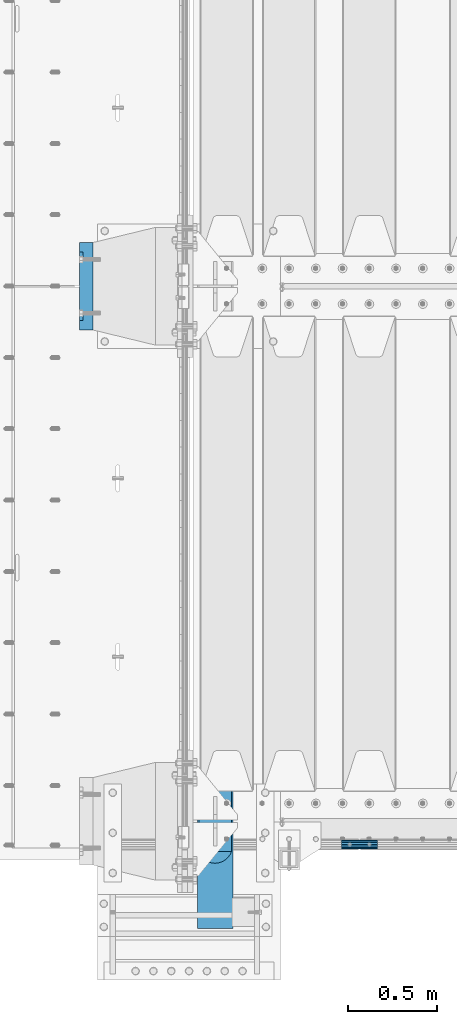
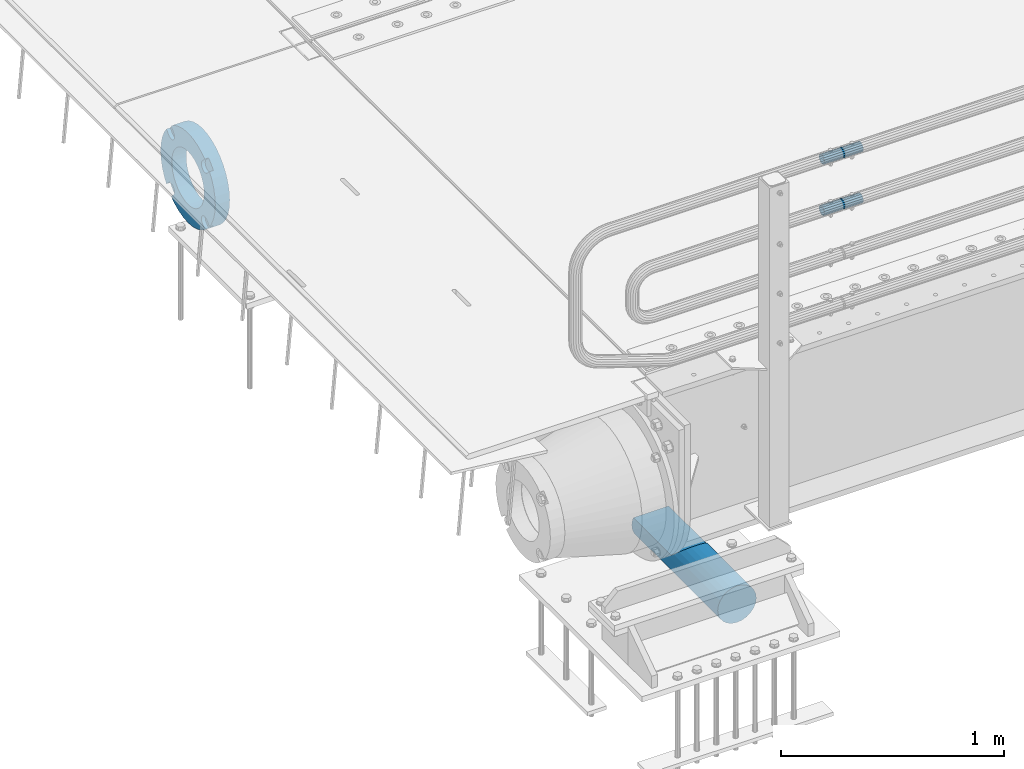
# One storey, part 138 of 257: 4 beams.
"""IFC2X3 building model written with IfcOpenShell, lengths in millimetres."""

from ifc_helpers import new_model, si_unit, frame, origin_with_axes, place, context, subcontext, project, spatial, faceted_brep, material, type_object, element, save


model = new_model("IFC2X3")

# Units and contexts
model_context = context("Model", 3, precision=1e-05, world=origin_with_axes())
body_context = subcontext(model_context, "Body", "Model", "MODEL_VIEW")
ifc_project = project(units=[si_unit("LENGTHUNIT", "METRE", prefix="MILLI"), si_unit("AREAUNIT", "SQUARE_METRE"), si_unit("VOLUMEUNIT", "CUBIC_METRE"), si_unit("MASSUNIT", "GRAM", prefix="KILO"), si_unit("TIMEUNIT", "SECOND"), si_unit("PLANEANGLEUNIT", "RADIAN"), si_unit("SOLIDANGLEUNIT", "STERADIAN"), si_unit("THERMODYNAMICTEMPERATUREUNIT", "DEGREE_CELSIUS"), si_unit("LUMINOUSINTENSITYUNIT", "LUMEN")], contexts=[model_context])

# Site, building, storey
site_placement = place(None, origin_with_axes())
site = spatial("IfcSite", under=ifc_project, at=site_placement, CompositionType="ELEMENT")
building_placement = place(site_placement, origin_with_axes())
building = spatial("IfcBuilding", under=site, at=building_placement, Name="Standard", CompositionType="ELEMENT")
storey_placement = place(building_placement, origin_with_axes())
storey = spatial("IfcBuildingStorey", under=building, at=storey_placement, Name="Undefined", CompositionType="ELEMENT", Elevation=0.0)

# Beams
ifc_material_1 = material(Name="STEEL/S355N")
beam_type_1 = type_object("IfcBeamType", Name="D200", PredefinedType="NOTDEFINED")
beam_1_placement = place(storey_placement, frame((42585.0, -600.0, -928.0), z_axis=(0.0, 0.0, 1.0), x_axis=(0.0, 1.0, 0.0)))
element("IfcBeam", 1, at=beam_1_placement, inside=storey, type_object=beam_type_1, material=ifc_material_1, ObjectType="D200", context=body_context, shape_type="Brep", body=[
    faceted_brep([(417.294117647059, 86.6025403784442, 50.0), (395.365164344954, 70.7106781186521, 70.7106781186548), (378.538486658119, 50.0, 86.6025403784439), (367.960794863511, 25.88190451025, 96.5925826289068), (364.352941176472, 0.0, 100.0), (367.960794863511, -25.88190451025, 96.5925826289068), (378.538486658119, -50.0, 86.6025403784439), (395.365164344954, -70.7106781186521, 70.7106781186548), (417.294117647059, -86.6025403784442, 50.0), (430.0, -91.5731031269243, 38.0), (430.0, 91.5731031269243, 38.0), (770.0, -91.5731031269243, 37.9999999999994), (770.0, 91.5731031269243, 37.9999999999994), (0.0, -96.5925826289094, 25.8819045102521), (0.0, -86.6025403784442, 50.0), (0.0, -70.7106781186521, 70.7106781186548), (0.0, -50.0, 86.6025403784439), (0.0, -25.88190451025, 96.5925826289068), (0.0, 0.0, 100.0), (0.0, 25.88190451025, 96.5925826289068), (0.0, 50.0, 86.6025403784439), (0.0, 70.7106781186521, 70.7106781186548), (0.0, 86.6025403784442, 50.0), (0.0, 96.5925826289094, 25.8819045102521), (0.0, 100.0, 0.0), (0.0, 96.5925826289094, -25.8819045102521), (0.0, 86.6025403784442, -50.0), (0.0, 70.7106781186521, -70.7106781186548), (0.0, 50.0, -86.6025403784438), (0.0, 25.88190451025, -96.5925826289067), (0.0, 0.0, -100.0), (0.0, -25.88190451025, -96.5925826289069), (0.0, -50.0, -86.6025403784439), (0.0, -70.7106781186521, -70.7106781186548), (0.0, -86.6025403784442, -50.0), (0.0, -96.5925826289094, -25.8819045102522), (0.0, -100.0, 0.0), (770.0, 96.5925826289094, 25.8819045102521), (770.0, 100.0, 0.0), (770.0, 96.5925826289094, -25.8819045102521), (770.0, 86.6025403784442, -50.0), (770.0, 70.7106781186521, -70.7106781186548), (770.0, 50.0, -86.6025403784438), (770.0, 25.88190451025, -96.5925826289067), (770.0, 0.0, -100.0), (770.0, -25.88190451025, -96.5925826289069), (770.0, -50.0, -86.6025403784439), (770.0, -70.7106781186521, -70.7106781186548), (770.0, -86.6025403784442, -50.0), (770.0, -96.5925826289094, -25.8819045102522), (770.0, -100.0, 0.0), (770.0, -96.5925826289094, 25.8819045102521)], [[[0, 1, 2, 3, 4, 5, 6, 7, 8, 9, 10]], [[10, 9, 11, 12]], [[13, 14, 15, 16, 17, 18, 19, 20, 21, 22, 23, 24, 25, 26, 27, 28, 29, 30, 31, 32, 33, 34, 35, 36]], [[24, 23, 37, 38]], [[25, 24, 38, 39]], [[26, 25, 39, 40]], [[27, 26, 40, 41]], [[28, 27, 41, 42]], [[29, 28, 42, 43]], [[30, 29, 43, 44]], [[31, 30, 44, 45]], [[32, 31, 45, 46]], [[33, 32, 46, 47]], [[34, 33, 47, 48]], [[35, 34, 48, 49]], [[36, 35, 49, 50]], [[13, 36, 50, 51]], [[14, 13, 51, 11, 9, 8]], [[15, 14, 8, 7]], [[16, 15, 7, 6]], [[17, 16, 6, 5]], [[18, 17, 5, 4]], [[19, 18, 4, 3]], [[20, 19, 3, 2]], [[21, 20, 2, 1]], [[22, 21, 1, 0]], [[37, 23, 22, 0, 10, 12]], [[51, 50, 49, 48, 47, 46, 45, 44, 43, 42, 41, 40, 39, 38, 37, 12, 11]]]),
])
ifc_material_2 = material()
beam_type_2 = type_object("IfcBeamType", PredefinedType="NOTDEFINED")
beam_2_placement = place(storey_placement, frame((43294.9975029999, -129.849999999603, 969.849999999725), z_axis=(0.0, 0.0, 1.0), x_axis=(1.0, 0.0, 0.0)))
element("IfcBeam", 2, at=beam_2_placement, inside=storey, type_object=beam_type_2, material=ifc_material_2, context=body_context, shape_type="Brep", body=[
    faceted_brep([(0.0, -21.8999999999996, 0.0), (0.0, -20.232961761998, 8.38076716879547), (200.0, -20.232961761998, 8.38076716879547), (200.0, -21.8999999999996, 0.0), (0.0, -15.4856385079856, 15.4856385079854), (200.0, -15.4856385079856, 15.4856385079854), (0.0, -8.3807671687955, 20.2329617619972), (200.0, -8.3807671687955, 20.2329617619972), (0.0, 0.0, 21.9), (200.0, 0.0, 21.9), (0.0, 8.3807671687955, 20.2329617619972), (200.0, 8.3807671687955, 20.2329617619972), (0.0, 15.4856385079856, 15.4856385079854), (200.0, 15.4856385079856, 15.4856385079854), (0.0, 20.232961761998, 8.38076716879547), (200.0, 20.232961761998, 8.38076716879547), (0.0, 21.8999999999996, 0.0), (200.0, 21.8999999999996, 0.0), (0.0, 20.232961761998, -8.38076716879547), (200.0, 20.232961761998, -8.38076716879547), (0.0, 15.4856385079856, -15.4856385079854), (200.0, 15.4856385079856, -15.4856385079854), (0.0, 8.3807671687955, -20.2329617619972), (200.0, 8.3807671687955, -20.2329617619972), (0.0, 0.0, -21.9), (200.0, 0.0, -21.9), (0.0, -8.3807671687955, -20.2329617619972), (200.0, -8.3807671687955, -20.2329617619972), (0.0, -15.4856385079856, -15.4856385079854), (200.0, -15.4856385079856, -15.4856385079854), (0.0, -20.232961761998, -8.38076716879547), (200.0, -20.232961761998, -8.38076716879547), (0.0, -25.5, 0.0), (0.0, -23.5589280790373, -9.7584275253098), (200.0, -23.5589280790373, -9.7584275253098), (200.0, -25.5, 0.0), (0.0, -18.0312229202573, -18.031222920257), (200.0, -18.0312229202573, -18.031222920257), (0.0, -9.75842752531025, -23.5589280790378), (200.0, -9.75842752531025, -23.5589280790378), (0.0, 0.0, -25.5), (200.0, 0.0, -25.5), (0.0, 9.75842752531025, -23.5589280790378), (200.0, 9.75842752531025, -23.5589280790378), (0.0, 18.0312229202573, -18.031222920257), (200.0, 18.0312229202573, -18.031222920257), (0.0, 23.5589280790373, -9.7584275253098), (200.0, 23.5589280790373, -9.7584275253098), (0.0, 25.5, 0.0), (200.0, 25.5, 0.0), (0.0, 23.5589280790373, 9.7584275253098), (200.0, 23.5589280790373, 9.7584275253098), (0.0, 18.0312229202573, 18.031222920257), (200.0, 18.0312229202573, 18.031222920257), (0.0, 9.75842752531025, 23.5589280790378), (200.0, 9.75842752531025, 23.5589280790378), (0.0, 0.0, 25.5), (200.0, 0.0, 25.5), (0.0, -9.75842752531025, 23.5589280790378), (200.0, -9.75842752531025, 23.5589280790378), (0.0, -18.0312229202573, 18.031222920257), (200.0, -18.0312229202573, 18.031222920257), (0.0, -23.5589280790373, 9.7584275253098), (200.0, -23.5589280790373, 9.7584275253098)], [[[0, 1, 2, 3]], [[1, 4, 5, 2]], [[4, 6, 7, 5]], [[6, 8, 9, 7]], [[8, 10, 11, 9]], [[10, 12, 13, 11]], [[12, 14, 15, 13]], [[14, 16, 17, 15]], [[16, 18, 19, 17]], [[18, 20, 21, 19]], [[20, 22, 23, 21]], [[22, 24, 25, 23]], [[24, 26, 27, 25]], [[26, 28, 29, 27]], [[28, 30, 31, 29]], [[30, 0, 3, 31]], [[32, 33, 34, 35]], [[33, 36, 37, 34]], [[36, 38, 39, 37]], [[38, 40, 41, 39]], [[40, 42, 43, 41]], [[42, 44, 45, 43]], [[44, 46, 47, 45]], [[46, 48, 49, 47]], [[48, 50, 51, 49]], [[50, 52, 53, 51]], [[52, 54, 55, 53]], [[54, 56, 57, 55]], [[56, 58, 59, 57]], [[58, 60, 61, 59]], [[60, 62, 63, 61]], [[62, 32, 35, 63]], [[37, 39, 41, 43, 45, 47, 49, 51, 53, 55, 57, 59, 61, 63, 35, 34], [5, 7, 9, 11, 13, 15, 17, 19, 21, 23, 25, 27, 29, 31, 3, 2]], [[62, 60, 58, 56, 54, 52, 50, 48, 46, 44, 42, 40, 38, 36, 33, 32], [30, 28, 26, 24, 22, 20, 18, 16, 14, 12, 10, 8, 6, 4, 1, 0]]]),
])
beam_3_placement = place(storey_placement, frame((43294.9975029999, -129.849999999603, 689.849999999725), z_axis=(0.0, 0.0, 1.0), x_axis=(1.0, 0.0, 0.0)))
element("IfcBeam", 3, at=beam_3_placement, inside=storey, type_object=beam_type_2, material=ifc_material_2, context=body_context, shape_type="Brep", body=[
    faceted_brep([(0.0, -21.8999999999996, 0.0), (0.0, -20.232961761998, 8.38076716879547), (200.0, -20.232961761998, 8.38076716879547), (200.0, -21.8999999999996, 0.0), (0.0, -15.4856385079856, 15.4856385079854), (200.0, -15.4856385079856, 15.4856385079854), (0.0, -8.3807671687955, 20.2329617619972), (200.0, -8.3807671687955, 20.2329617619972), (0.0, 0.0, 21.9), (200.0, 0.0, 21.9), (0.0, 8.3807671687955, 20.2329617619972), (200.0, 8.3807671687955, 20.2329617619972), (0.0, 15.4856385079856, 15.4856385079854), (200.0, 15.4856385079856, 15.4856385079854), (0.0, 20.232961761998, 8.38076716879547), (200.0, 20.232961761998, 8.38076716879547), (0.0, 21.8999999999996, 0.0), (200.0, 21.8999999999996, 0.0), (0.0, 20.232961761998, -8.38076716879547), (200.0, 20.232961761998, -8.38076716879547), (0.0, 15.4856385079856, -15.4856385079854), (200.0, 15.4856385079856, -15.4856385079854), (0.0, 8.3807671687955, -20.2329617619972), (200.0, 8.3807671687955, -20.2329617619972), (0.0, 0.0, -21.9), (200.0, 0.0, -21.9), (0.0, -8.3807671687955, -20.2329617619972), (200.0, -8.3807671687955, -20.2329617619972), (0.0, -15.4856385079856, -15.4856385079854), (200.0, -15.4856385079856, -15.4856385079854), (0.0, -20.232961761998, -8.38076716879547), (200.0, -20.232961761998, -8.38076716879547), (0.0, -25.5, 0.0), (0.0, -23.5589280790373, -9.7584275253098), (200.0, -23.5589280790373, -9.7584275253098), (200.0, -25.5, 0.0), (0.0, -18.0312229202573, -18.031222920257), (200.0, -18.0312229202573, -18.031222920257), (0.0, -9.75842752531025, -23.5589280790378), (200.0, -9.75842752531025, -23.5589280790378), (0.0, 0.0, -25.5), (200.0, 0.0, -25.5), (0.0, 9.75842752531025, -23.5589280790378), (200.0, 9.75842752531025, -23.5589280790378), (0.0, 18.0312229202573, -18.031222920257), (200.0, 18.0312229202573, -18.031222920257), (0.0, 23.5589280790373, -9.7584275253098), (200.0, 23.5589280790373, -9.7584275253098), (0.0, 25.5, 0.0), (200.0, 25.5, 0.0), (0.0, 23.5589280790373, 9.7584275253098), (200.0, 23.5589280790373, 9.7584275253098), (0.0, 18.0312229202573, 18.031222920257), (200.0, 18.0312229202573, 18.031222920257), (0.0, 9.75842752531025, 23.5589280790378), (200.0, 9.75842752531025, 23.5589280790378), (0.0, 0.0, 25.5), (200.0, 0.0, 25.5), (0.0, -9.75842752531025, 23.5589280790378), (200.0, -9.75842752531025, 23.5589280790378), (0.0, -18.0312229202573, 18.031222920257), (200.0, -18.0312229202573, 18.031222920257), (0.0, -23.5589280790373, 9.7584275253098), (200.0, -23.5589280790373, 9.7584275253098)], [[[0, 1, 2, 3]], [[1, 4, 5, 2]], [[4, 6, 7, 5]], [[6, 8, 9, 7]], [[8, 10, 11, 9]], [[10, 12, 13, 11]], [[12, 14, 15, 13]], [[14, 16, 17, 15]], [[16, 18, 19, 17]], [[18, 20, 21, 19]], [[20, 22, 23, 21]], [[22, 24, 25, 23]], [[24, 26, 27, 25]], [[26, 28, 29, 27]], [[28, 30, 31, 29]], [[30, 0, 3, 31]], [[32, 33, 34, 35]], [[33, 36, 37, 34]], [[36, 38, 39, 37]], [[38, 40, 41, 39]], [[40, 42, 43, 41]], [[42, 44, 45, 43]], [[44, 46, 47, 45]], [[46, 48, 49, 47]], [[48, 50, 51, 49]], [[50, 52, 53, 51]], [[52, 54, 55, 53]], [[54, 56, 57, 55]], [[56, 58, 59, 57]], [[58, 60, 61, 59]], [[60, 62, 63, 61]], [[62, 32, 35, 63]], [[37, 39, 41, 43, 45, 47, 49, 51, 53, 55, 57, 59, 61, 63, 35, 34], [5, 7, 9, 11, 13, 15, 17, 19, 21, 23, 25, 27, 29, 31, 3, 2]], [[62, 60, 58, 56, 54, 52, 50, 48, 46, 44, 42, 40, 38, 36, 33, 32], [30, 28, 26, 24, 22, 20, 18, 16, 14, 12, 10, 8, 6, 4, 1, 0]]]),
])
ifc_material_3 = material(Name="SCN-500-E2")
beam_type_3 = type_object("IfcBeamType", PredefinedType="NOTDEFINED")
beam_4_placement = place(storey_placement, frame((41900.0, 3000.00000146624, -515.0), z_axis=(0.0, 0.0, 1.0), x_axis=(-1.0, 0.0, 0.0)))
element("IfcBeam", 4, at=beam_4_placement, inside=storey, type_object=beam_type_3, material=ifc_material_3, context=body_context, shape_type="Brep", body=[
    faceted_brep([(75.0, 192.717024793295, -150.290616455866), (75.0000000000073, 171.473395903973, -129.046987566545), (55.0, 171.473395903973, -129.046987566545), (55.0, 192.717024793295, -150.290616455866), (75.0000000000073, 167.467485558908, -125.685629673472), (55.0, 167.467485558908, -125.685629673472), (75.0000000000073, 162.938740320598, -123.070957391043), (55.0, 162.938740320598, -123.070957391043), (75.0000000000073, 158.024763821452, -121.28241621347), (55.0, 158.024763821452, -121.28241621347), (75.0000000000073, 152.874864750806, -120.37435005939), (55.0, 152.874864750806, -120.37435005939), (75.0000000000073, 147.645520185947, -120.37435005939), (55.0, 147.645520185947, -120.37435005939), (75.0000000000073, 142.495621115301, -121.28241621347), (55.0, 142.495621115301, -121.28241621347), (75.0000000000073, 137.581644616156, -123.070957391043), (55.0, 137.581644616156, -123.070957391043), (75.0000000000073, 133.052899377846, -125.685629673472), (55.0, 133.052899377846, -125.685629673472), (75.0000000000073, 129.04698903278, -129.046987566545), (55.0, 129.04698903278, -129.046987566545), (75.0000000000073, 125.685631139707, -133.05289791161), (55.0, 125.685631139707, -133.05289791161), (75.0000000000073, 123.070958857277, -137.58164314992), (55.0, 123.070958857277, -137.58164314992), (75.0000000000073, 121.282417679704, -142.495619649066), (55.0, 121.282417679704, -142.495619649066), (75.0, 120.374351525624, -147.645518719712), (55.0, 120.374351525624, -147.645518719712), (75.0, 120.374351525624, -152.874863284572), (55.0, 120.374351525624, -152.874863284572), (75.0000000000073, 121.282417679704, -158.024762355218), (55.0, 121.282417679704, -158.024762355218), (75.0000000000073, 123.070958857277, -162.938738854363), (55.0, 123.070958857277, -162.938738854363), (75.0000000000073, 125.685631139707, -167.467484092674), (55.0, 125.685631139707, -167.467484092674), (75.0000000000073, 129.04698903278, -171.473394437738), (55.0, 129.04698903278, -171.473394437738), (55.0, 150.290618180639, -192.717023585596), (75.0, 150.290618180639, -192.717023585596), (55.0, 157.482964373202, -187.68088856415), (55.0, 187.68088856415, -157.482964373202), (75.0, -192.717023585595, 150.29061818064), (75.0000000000073, -171.4733929715, 129.046987566545), (55.0, -171.4733929715, 129.046987566545), (55.0, -192.717023585596, 150.29061818064), (75.0000000000073, -167.467482626435, 125.685629673472), (55.0, -167.467482626435, 125.685629673472), (75.0000000000073, -162.938737388125, 123.070957391043), (55.0, -162.938737388125, 123.070957391043), (75.0000000000073, -158.024760888979, 121.28241621347), (55.0, -158.024760888979, 121.28241621347), (75.0000000000073, -152.874861818334, 120.37435005939), (55.0, -152.874861818334, 120.37435005939), (75.0000000000073, -147.645517253474, 120.37435005939), (55.0, -147.645517253474, 120.37435005939), (75.0000000000073, -142.495618182828, 121.28241621347), (55.0, -142.495618182828, 121.28241621347), (75.0, -137.581641683683, 123.070957391043), (55.0, -137.581641683683, 123.070957391043), (75.0, -133.052896445373, 125.685629673473), (55.0, -133.052896445373, 125.685629673473), (75.0, -129.046986100308, 129.046987566545), (55.0, -129.046986100308, 129.046987566545), (75.0, -125.685628207234, 133.05289791161), (55.0, -125.685628207234, 133.05289791161), (75.0, -123.070955924804, 137.581643149921), (55.0, -123.070955924804, 137.581643149921), (75.0, -121.282414747231, 142.495619649066), (55.0, -121.282414747231, 142.495619649066), (75.0, -120.374348593151, 147.645518719712), (55.0, -120.374348593151, 147.645518719712), (75.0, -120.374348593151, 152.874863284572), (55.0, -120.374348593151, 152.874863284572), (75.0, -121.282414747231, 158.024762355218), (55.0, -121.282414747231, 158.024762355218), (75.0, -123.070955924804, 162.938738854364), (55.0, -123.070955924804, 162.938738854364), (75.0, -125.685628207234, 167.467484092675), (55.0, -125.685628207234, 167.467484092675), (75.0, -129.046986100308, 171.473394437738), (55.0, -129.046986100308, 171.473394437738), (55.0, -150.290616455865, 192.717024793296), (75.0, -150.290616455865, 192.717024793296), (75.0, 150.290618180638, 192.717023585597), (75.0, 129.04698903278, 171.473394437739), (55.0, 129.04698903278, 171.473394437739), (55.0, 150.290618180638, 192.717023585597), (75.0, 125.685631139708, 167.467484092674), (55.0, 125.685631139708, 167.467484092674), (75.0, 123.070958857278, 162.938738854363), (55.0, 123.070958857278, 162.938738854363), (75.0, 121.282417679706, 158.024762355218), (55.0, 121.282417679706, 158.024762355218), (75.0, 120.374351525625, 152.874863284572), (55.0, 120.374351525625, 152.874863284572), (75.0, 120.374351525625, 147.645518719713), (55.0, 120.374351525625, 147.645518719713), (75.0, 121.282417679706, 142.495619649067), (55.0, 121.282417679706, 142.495619649067), (75.0, 123.070958857278, 137.581643149922), (55.0, 123.070958857278, 137.581643149922), (75.0, 125.685631139708, 133.052897911612), (55.0, 125.685631139708, 133.052897911612), (75.0, 129.04698903278, 129.046987566546), (55.0, 129.04698903278, 129.046987566546), (75.0, 133.052899377845, 125.685629673472), (55.0, 133.052899377845, 125.685629673472), (75.0, 137.581644616156, 123.070957391043), (55.0, 137.581644616156, 123.070957391043), (75.0, 142.495621115301, 121.28241621347), (55.0, 142.495621115301, 121.28241621347), (75.0, 147.645520185948, 120.37435005939), (55.0, 147.645520185948, 120.37435005939), (75.0, 152.874864750807, 120.37435005939), (55.0, 152.874864750807, 120.37435005939), (75.0, 158.024763821453, 121.28241621347), (55.0, 158.024763821453, 121.28241621347), (75.0, 162.938740320599, 123.070957391043), (55.0, 162.938740320599, 123.070957391043), (75.0, 167.46748555891, 125.685629673472), (55.0, 167.46748555891, 125.685629673472), (75.0, 171.473395903973, 129.046987566546), (55.0, 171.473395903973, 129.046987566546), (55.0, 192.717024793294, 150.290616455867), (75.0, 192.717024793294, 150.290616455867), (0.0, 212.176223927188, -122.5), (0.0, 230.224692092548, -83.7949351147888), (75.0, 230.224692092548, -83.7949351147888), (75.0, 212.176223927188, -122.5), (0.0, 241.277899487991, -42.5438035283978), (75.0, 241.277899487991, -42.5438035283978), (0.0, 245.0, 0.0), (75.0, 245.0, 0.0), (0.0, 241.277899487991, 42.543803528398), (75.0, 241.277899487991, 42.543803528398), (0.0, 230.224692092548, 83.7949351147889), (75.0, 230.224692092548, 83.7949351147889), (0.0, 212.176223927187, 122.5), (75.0, 212.176223927187, 122.5), (0.0, 187.68088856415, 157.482964373202), (55.0, 187.68088856415, 157.482964373202), (0.0, 157.482964373202, 187.68088856415), (55.0, 157.482964373202, 187.68088856415), (0.0, 122.5, 212.176223927187), (75.0, 122.5, 212.176223927187), (0.0, 83.7949351147888, 230.224692092548), (75.0, 83.7949351147888, 230.224692092548), (0.0, 42.5438035283979, 241.277899487991), (75.0, 42.5438035283979, 241.277899487991), (0.0, -1.50019233485983e-14, 245.0), (75.0, -1.50019233485983e-14, 245.0), (0.0, -42.543803528398, 241.277899487991), (75.0, -42.543803528398, 241.277899487991), (0.0, -83.7949351147889, 230.224692092548), (75.0, -83.7949351147889, 230.224692092548), (0.0, -122.5, 212.176223927187), (75.0, -122.5, 212.176223927187), (0.0, -157.482964373202, 187.68088856415), (55.0, -157.482964373202, 187.68088856415), (0.0, -187.68088856415, 157.482964373202), (55.0, -187.68088856415, 157.482964373202), (0.0, -212.176223927187, 122.5), (75.0, -212.176223927187, 122.5), (0.0, -230.224692092548, 83.7949351147888), (75.0, -230.224692092548, 83.7949351147888), (0.0, -241.277899487991, 42.5438035283979), (75.0, -241.277899487991, 42.5438035283979), (0.0, -245.0, 0.0), (75.0, -245.0, 0.0), (0.0, -187.68088856415, -157.482964373202), (0.0, -157.482964373202, -187.68088856415), (55.0, -157.482964373202, -187.68088856415), (55.0, -187.68088856415, -157.482964373202), (0.0, 83.794935114789, -230.224692092547), (0.0, 122.5, -212.176223927187), (75.0, 122.5, -212.176223927187), (75.0, 83.794935114789, -230.224692092547), (0.0, 42.5438035283979, -241.277899487991), (75.0, 42.5438035283979, -241.277899487991), (0.0, 4.50057698340366e-14, -245.0), (75.0, 4.50057698340366e-14, -245.0), (0.0, -42.5438035283978, -241.277899487991), (75.0, -42.5438035283978, -241.277899487991), (0.0, -83.7949351147887, -230.224692092548), (75.0, -83.7949351147887, -230.224692092548), (0.0, -122.5, -212.176223927187), (75.0, -122.5, -212.176223927187), (75.0, -150.290616455865, -192.717024793296), (55.0, -150.290616455865, -192.717024793296), (55.0, -129.046986100307, -171.473394437739), (55.0, -125.685628207235, -167.467484092674), (55.0, -123.070955924805, -162.938738854363), (55.0, -121.282414747233, -158.024762355218), (55.0, -120.374348593152, -152.874863284572), (55.0, -120.374348593153, -147.645518719713), (55.0, -121.282414747233, -142.495619649067), (55.0, -123.070955924805, -137.581643149922), (55.0, -125.685628207235, -133.052897911612), (55.0, -129.046986100307, -129.046987566546), (55.0, -133.052896445372, -125.685629673472), (55.0, -137.581641683683, -123.070957391043), (55.0, -142.495618182829, -121.28241621347), (55.0, -147.645517253475, -120.37435005939), (55.0, -152.874861818334, -120.37435005939), (55.0, -158.024760888981, -121.28241621347), (55.0, -162.938737388126, -123.070957391043), (55.0, -167.467482626437, -125.685629673472), (55.0, -171.4733929715, -129.046987566546), (55.0, -192.717023585595, -150.290618180641), (75.0, -129.046986100307, -171.473394437739), (75.0, -125.685628207235, -167.467484092674), (75.0, -123.070955924805, -162.938738854363), (75.0, -121.282414747233, -158.024762355218), (75.0, -120.374348593152, -152.874863284572), (75.0, -120.374348593153, -147.645518719713), (75.0, -121.282414747233, -142.495619649067), (75.0, -123.070955924805, -137.581643149922), (75.0, -125.685628207235, -133.052897911612), (75.0, -129.046986100307, -129.046987566546), (75.0, -133.052896445372, -125.685629673472), (75.0, -137.581641683683, -123.070957391043), (75.0, -142.495618182829, -121.28241621347), (75.0, -147.645517253475, -120.37435005939), (75.0, -152.874861818334, -120.37435005939), (75.0, -158.024760888981, -121.28241621347), (75.0, -162.938737388126, -123.070957391043), (75.0, -167.467482626437, -125.685629673472), (75.0, -171.4733929715, -129.046987566546), (75.0, -192.717023585595, -150.290618180641), (75.0, -212.176223927187, -122.5), (0.0, -212.176223927187, -122.5), (0.0, -230.224692092547, -83.794935114789), (75.0, -230.224692092547, -83.794935114789), (0.0, -241.277899487991, -42.5438035283979), (75.0, -241.277899487991, -42.5438035283979), (0.0, 187.68088856415, -157.482964373202), (0.0, 157.482964373202, -187.68088856415), (0.0, -142.79712418677, -25.1789857617049), (0.0, -136.255430013957, -49.592920782222), (0.0, -125.573683548744, -72.5), (0.0, -111.076444252252, -93.2042034045483), (0.0, -93.2042034045482, -111.076444252252), (0.0, -72.5, -125.573683548744), (0.0, -49.592920782222, -136.255430013957), (0.0, -25.1789857617049, -142.79712418677), (0.0, -8.87868935037022e-15, -145.0), (0.0, 25.1789857617049, -142.79712418677), (0.0, 49.592920782222, -136.255430013957), (0.0, 72.5, -125.573683548744), (0.0, 93.2042034045482, -111.076444252252), (0.0, 111.076444252252, -93.2042034045483), (0.0, 125.573683548744, -72.5), (0.0, 136.255430013957, -49.592920782222), (0.0, 142.79712418677, -25.178985761705), (0.0, 145.0, 0.0), (0.0, 142.79712418677, 25.1789857617048), (0.0, 136.255430013957, 49.5929207822219), (0.0, 125.573683548744, 72.4999999999999), (0.0, 111.076444252252, 93.2042034045482), (0.0, 93.2042034045482, 111.076444252252), (0.0, 72.5000000000001, 125.573683548744), (0.0, 49.5929207822221, 136.255430013957), (0.0, 25.1789857617049, 142.79712418677), (0.0, 2.66360678393524e-14, 145.0), (0.0, -25.1789857617048, 142.79712418677), (0.0, -49.5929207822219, 136.255430013957), (0.0, -72.5, 125.573683548744), (0.0, -93.2042034045482, 111.076444252252), (0.0, -111.076444252252, 93.2042034045483), (0.0, -125.573683548744, 72.5000000000001), (0.0, -136.255430013957, 49.5929207822221), (0.0, -142.79712418677, 25.1789857617049), (0.0, -145.0, 0.0), (75.0, -145.0, 0.0), (75.0, -142.79712418677, -25.1789857617049), (75.0, -136.255430013957, -49.592920782222), (75.0, -125.573683548744, -72.5), (75.0, -111.076444252252, -93.2042034045483), (75.0, -93.2042034045482, -111.076444252252), (75.0, -72.5, -125.573683548744), (75.0, -49.592920782222, -136.255430013957), (75.0, -25.1789857617049, -142.79712418677), (75.0, -8.87868935037022e-15, -145.0), (75.0, 25.1789857617049, -142.79712418677), (75.0, 49.592920782222, -136.255430013957), (75.0, 72.5, -125.573683548744), (75.0, 93.2042034045482, -111.076444252252), (75.0, 111.076444252252, -93.2042034045483), (75.0, 125.573683548744, -72.5), (75.0, 136.255430013957, -49.592920782222), (75.0, 142.79712418677, -25.178985761705), (75.0, 145.0, 0.0), (75.0, 142.79712418677, 25.1789857617048), (75.0, 136.255430013957, 49.5929207822219), (75.0, 125.573683548744, 72.4999999999999), (75.0, 111.076444252252, 93.2042034045482), (75.0, 93.2042034045482, 111.076444252252), (75.0, 72.5000000000001, 125.573683548744), (75.0, 49.5929207822221, 136.255430013957), (75.0, 25.1789857617049, 142.79712418677), (75.0, 2.66360678393524e-14, 145.0), (75.0, -25.1789857617048, 142.79712418677), (75.0, -49.5929207822219, 136.255430013957), (75.0, -72.5, 125.573683548744), (75.0, -93.2042034045482, 111.076444252252), (75.0, -111.076444252252, 93.2042034045483), (75.0, -125.573683548744, 72.5000000000001), (75.0, -136.255430013957, 49.5929207822221), (75.0, -142.79712418677, 25.1789857617049)], [[[0, 1, 2, 3]], [[4, 5, 2, 1]], [[6, 7, 5, 4]], [[8, 9, 7, 6]], [[10, 11, 9, 8]], [[12, 13, 11, 10]], [[14, 15, 13, 12]], [[16, 17, 15, 14]], [[18, 19, 17, 16]], [[20, 21, 19, 18]], [[22, 23, 21, 20]], [[24, 25, 23, 22]], [[26, 27, 25, 24]], [[28, 29, 27, 26]], [[30, 31, 29, 28]], [[32, 33, 31, 30]], [[34, 35, 33, 32]], [[36, 37, 35, 34]], [[38, 39, 37, 36]], [[40, 39, 38, 41]], [[42, 43, 3, 2, 5, 7, 9, 11, 13, 15, 17, 19, 21, 23, 25, 27, 29, 31, 33, 35, 37, 39, 40]], [[44, 45, 46, 47]], [[48, 49, 46, 45]], [[50, 51, 49, 48]], [[52, 53, 51, 50]], [[54, 55, 53, 52]], [[56, 57, 55, 54]], [[58, 59, 57, 56]], [[60, 61, 59, 58]], [[62, 63, 61, 60]], [[64, 65, 63, 62]], [[66, 67, 65, 64]], [[68, 69, 67, 66]], [[70, 71, 69, 68]], [[72, 73, 71, 70]], [[74, 75, 73, 72]], [[76, 77, 75, 74]], [[78, 79, 77, 76]], [[80, 81, 79, 78]], [[82, 83, 81, 80]], [[84, 83, 82, 85]], [[86, 87, 88, 89]], [[90, 91, 88, 87]], [[92, 93, 91, 90]], [[94, 95, 93, 92]], [[96, 97, 95, 94]], [[98, 99, 97, 96]], [[100, 101, 99, 98]], [[102, 103, 101, 100]], [[104, 105, 103, 102]], [[106, 107, 105, 104]], [[108, 109, 107, 106]], [[110, 111, 109, 108]], [[112, 113, 111, 110]], [[114, 115, 113, 112]], [[116, 117, 115, 114]], [[118, 119, 117, 116]], [[120, 121, 119, 118]], [[122, 123, 121, 120]], [[124, 125, 123, 122]], [[126, 125, 124, 127]], [[128, 129, 130, 131]], [[129, 132, 133, 130]], [[132, 134, 135, 133]], [[134, 136, 137, 135]], [[136, 138, 139, 137]], [[138, 140, 141, 139]], [[127, 141, 140, 142, 143, 126]], [[142, 144, 145, 143]], [[89, 88, 91, 93, 95, 97, 99, 101, 103, 105, 107, 109, 111, 113, 115, 117, 119, 121, 123, 125, 126, 143, 145]], [[144, 146, 147, 86, 89, 145]], [[146, 148, 149, 147]], [[148, 150, 151, 149]], [[150, 152, 153, 151]], [[152, 154, 155, 153]], [[154, 156, 157, 155]], [[156, 158, 159, 157]], [[85, 159, 158, 160, 161, 84]], [[160, 162, 163, 161]], [[47, 46, 49, 51, 53, 55, 57, 59, 61, 63, 65, 67, 69, 71, 73, 75, 77, 79, 81, 83, 84, 161, 163]], [[162, 164, 165, 44, 47, 163]], [[164, 166, 167, 165]], [[166, 168, 169, 167]], [[168, 170, 171, 169]], [[172, 173, 174, 175]], [[176, 177, 178, 179]], [[180, 176, 179, 181]], [[182, 180, 181, 183]], [[184, 182, 183, 185]], [[186, 184, 185, 187]], [[188, 186, 187, 189]], [[173, 188, 189, 190, 191, 174]], [[175, 174, 191, 192, 193, 194, 195, 196, 197, 198, 199, 200, 201, 202, 203, 204, 205, 206, 207, 208, 209, 210, 211]], [[190, 212, 192, 191]], [[213, 193, 192, 212]], [[214, 194, 193, 213]], [[215, 195, 194, 214]], [[216, 196, 195, 215]], [[217, 197, 196, 216]], [[218, 198, 197, 217]], [[219, 199, 198, 218]], [[220, 200, 199, 219]], [[221, 201, 200, 220]], [[222, 202, 201, 221]], [[223, 203, 202, 222]], [[224, 204, 203, 223]], [[225, 205, 204, 224]], [[226, 206, 205, 225]], [[227, 207, 206, 226]], [[228, 208, 207, 227]], [[229, 209, 208, 228]], [[230, 210, 209, 229]], [[211, 210, 230, 231]], [[232, 233, 172, 175, 211, 231]], [[234, 233, 232, 235]], [[236, 234, 235, 237]], [[170, 236, 237, 171]], [[168, 166, 164, 162, 160, 158, 156, 154, 152, 150, 148, 146, 144, 142, 140, 138, 136, 134, 132, 129, 128, 238, 239, 177, 176, 180, 182, 184, 186, 188, 173, 172, 233, 234, 236, 170], [240, 241, 242, 243, 244, 245, 246, 247, 248, 249, 250, 251, 252, 253, 254, 255, 256, 257, 258, 259, 260, 261, 262, 263, 264, 265, 266, 267, 268, 269, 270, 271, 272, 273, 274, 275]], [[240, 275, 276, 277]], [[241, 240, 277, 278]], [[242, 241, 278, 279]], [[243, 242, 279, 280]], [[244, 243, 280, 281]], [[245, 244, 281, 282]], [[246, 245, 282, 283]], [[247, 246, 283, 284]], [[248, 247, 284, 285]], [[249, 248, 285, 286]], [[250, 249, 286, 287]], [[251, 250, 287, 288]], [[252, 251, 288, 289]], [[253, 252, 289, 290]], [[254, 253, 290, 291]], [[255, 254, 291, 292]], [[256, 255, 292, 293]], [[257, 256, 293, 294]], [[258, 257, 294, 295]], [[259, 258, 295, 296]], [[260, 259, 296, 297]], [[261, 260, 297, 298]], [[262, 261, 298, 299]], [[263, 262, 299, 300]], [[264, 263, 300, 301]], [[265, 264, 301, 302]], [[266, 265, 302, 303]], [[267, 266, 303, 304]], [[268, 267, 304, 305]], [[269, 268, 305, 306]], [[270, 269, 306, 307]], [[271, 270, 307, 308]], [[272, 271, 308, 309]], [[273, 272, 309, 310]], [[274, 273, 310, 311]], [[275, 274, 311, 276]], [[24, 22, 20, 18, 16, 14, 12, 10, 8, 6, 4, 1, 0, 131, 130, 133, 135, 137, 139, 141, 127, 124, 122, 120, 118, 116, 114, 112, 110, 108, 106, 104, 102, 100, 98, 96, 94, 92, 90, 87, 86, 147, 149, 151, 153, 155, 157, 159, 85, 82, 80, 78, 76, 74, 72, 70, 68, 66, 64, 62, 60, 58, 56, 54, 52, 50, 48, 45, 44, 165, 167, 169, 171, 237, 235, 232, 231, 230, 229, 228, 227, 226, 225, 224, 223, 222, 221, 220, 219, 218, 217, 216, 215, 214, 213, 212, 190, 189, 187, 185, 183, 181, 179, 178, 41, 38, 36, 34, 32, 30, 28, 26], [310, 309, 308, 307, 306, 305, 304, 303, 302, 301, 300, 299, 298, 297, 296, 295, 294, 293, 292, 291, 290, 289, 288, 287, 286, 285, 284, 283, 282, 281, 280, 279, 278, 277, 276, 311]], [[238, 128, 131, 0, 3, 43]], [[239, 238, 43, 42]], [[178, 177, 239, 42, 40, 41]]]),
])

save(model, "model.ifc")
